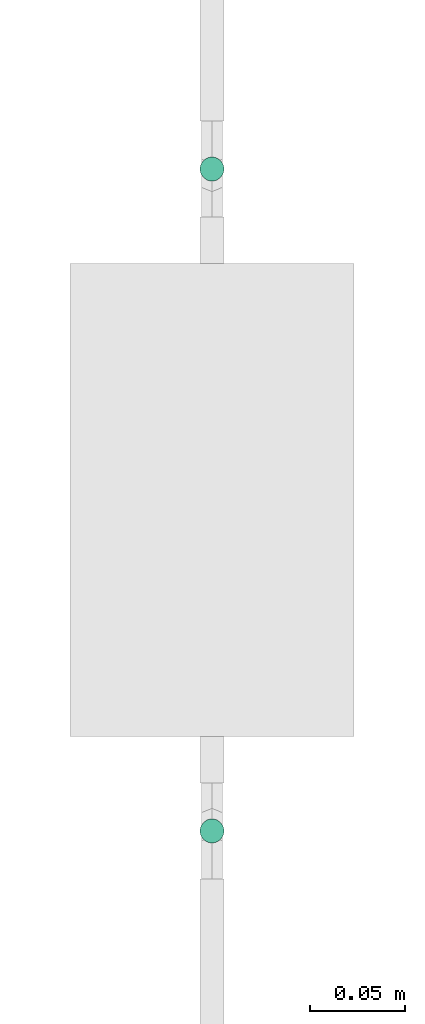
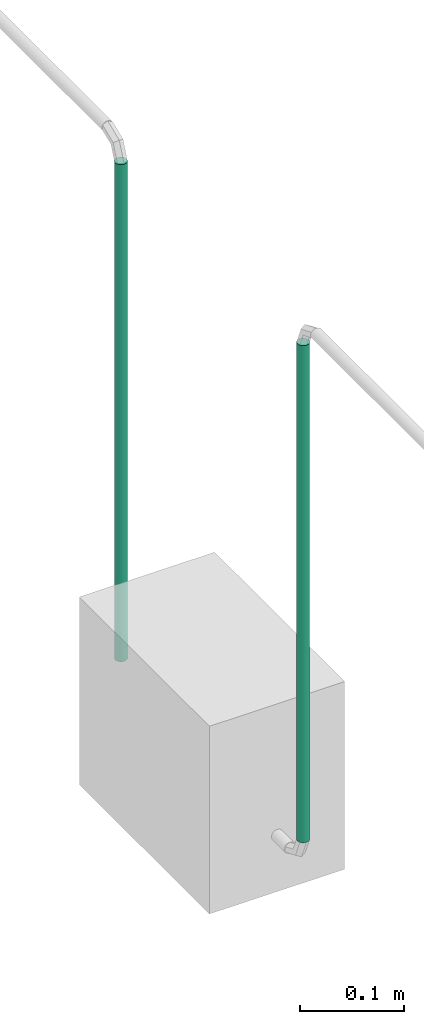
# One storey, part 18 of 45: 2 flow segments.
"""IFC2X3 building model written with IfcOpenShell, lengths in millimetres."""

from ifc_helpers import new_model, entity, si_unit, converted_unit, derived_unit, direction, frame, origin, origin_2d_with_axis, place, context, subcontext, project, spatial, circle, extrude, type_object, element, save


model = new_model("IFC2X3")

# Units and contexts
model_context = context("Model", 3, precision=0.01, world=origin(), true_north=direction((6.12303176911189e-17, 1.0)))
body_context = subcontext(model_context, "Body", "Model", "MODEL_VIEW")
ifc_project = project(units=[si_unit("LENGTHUNIT", "METRE", prefix="MILLI"), si_unit("AREAUNIT", "SQUARE_METRE"), si_unit("VOLUMEUNIT", "CUBIC_METRE"), converted_unit("PLANEANGLEUNIT", "DEGREE", entity("IfcRatioMeasure", 0.0174532925199433), si_unit("PLANEANGLEUNIT", "RADIAN"), dimensions=[0, 0, 0, 0, 0, 0, 0]), si_unit("MASSUNIT", "GRAM", prefix="KILO"), derived_unit("MASSDENSITYUNIT", [(si_unit("MASSUNIT", "GRAM", prefix="KILO"), 1), (si_unit("LENGTHUNIT", "METRE"), -3)]), derived_unit("MOMENTOFINERTIAUNIT", [(si_unit("LENGTHUNIT", "METRE"), 4)]), si_unit("TIMEUNIT", "SECOND"), si_unit("FREQUENCYUNIT", "HERTZ"), si_unit("THERMODYNAMICTEMPERATUREUNIT", "DEGREE_CELSIUS"), derived_unit("THERMALTRANSMITTANCEUNIT", [(si_unit("MASSUNIT", "GRAM", prefix="KILO"), 1), (si_unit("THERMODYNAMICTEMPERATUREUNIT", "KELVIN"), -1), (si_unit("TIMEUNIT", "SECOND"), -3)]), derived_unit("VOLUMETRICFLOWRATEUNIT", [(si_unit("LENGTHUNIT", "METRE"), 3), (si_unit("TIMEUNIT", "SECOND"), -1)]), derived_unit("MASSFLOWRATEUNIT", [(si_unit("MASSUNIT", "GRAM", prefix="KILO"), 1), (si_unit("TIMEUNIT", "SECOND"), -1)]), derived_unit("ROTATIONALFREQUENCYUNIT", [(si_unit("TIMEUNIT", "SECOND"), -1)]), si_unit("ELECTRICCURRENTUNIT", "AMPERE"), si_unit("ELECTRICVOLTAGEUNIT", "VOLT"), si_unit("POWERUNIT", "WATT"), si_unit("FORCEUNIT", "NEWTON", prefix="KILO"), si_unit("ILLUMINANCEUNIT", "LUX"), si_unit("LUMINOUSFLUXUNIT", "LUMEN"), si_unit("LUMINOUSINTENSITYUNIT", "CANDELA"), derived_unit("USERDEFINED", [(si_unit("MASSUNIT", "GRAM", prefix="KILO"), -1), (si_unit("LENGTHUNIT", "METRE"), -2), (si_unit("TIMEUNIT", "SECOND"), 3), (si_unit("LUMINOUSFLUXUNIT", "LUMEN"), 1)]), derived_unit("LINEARVELOCITYUNIT", [(si_unit("LENGTHUNIT", "METRE"), 1), (si_unit("TIMEUNIT", "SECOND"), -1)]), si_unit("PRESSUREUNIT", "PASCAL"), derived_unit("USERDEFINED", [(si_unit("LENGTHUNIT", "METRE"), -2), (si_unit("MASSUNIT", "GRAM", prefix="KILO"), 1), (si_unit("TIMEUNIT", "SECOND"), -2)]), derived_unit("LINEARFORCEUNIT", [(si_unit("MASSUNIT", "GRAM", prefix="KILO"), 1), (si_unit("LENGTHUNIT", "METRE"), 1), (si_unit("TIMEUNIT", "SECOND"), -2), (si_unit("LENGTHUNIT", "METRE"), -1)]), derived_unit("PLANARFORCEUNIT", [(si_unit("MASSUNIT", "GRAM", prefix="KILO"), 1), (si_unit("LENGTHUNIT", "METRE"), 1), (si_unit("TIMEUNIT", "SECOND"), -2), (si_unit("LENGTHUNIT", "METRE"), -2)])], contexts=[model_context])

# Site, building, storey
site_placement = place(None, frame((-24836.06, 8968.75, 0.0)))
site = spatial("IfcSite", under=ifc_project, at=site_placement, CompositionType="ELEMENT")
building_placement = place(site_placement, origin())
building = spatial("IfcBuilding", under=site, at=building_placement, CompositionType="ELEMENT")
storey_placement = place(building_placement, frame((0.0, 0.0, -4200.0)))
storey = spatial("IfcBuildingStorey", under=building, at=storey_placement, CompositionType="ELEMENT", Elevation=-4200.0)

# Flow segments
pipe_segment_type = type_object("IfcPipeSegmentType", PredefinedType="NOTDEFINED")
for number, where in (
    (1, (74862.81, -7251.7, 1591.88)),
    (2, (74862.81, -7601.7, 1591.88)),
):
    element("IfcFlowSegment", number, at=place(storey_placement, frame(where)), inside=storey, type_object=pipe_segment_type, context=body_context, shape_type="SweptSolid", body=[
        extrude(circle(Radius=6.35, at=origin_2d_with_axis()), frame((7.95, 7.95, 0.0)), (0.0, 0.0, 1.0), 582.722391317267),
    ])

save(model, "model.ifc")
